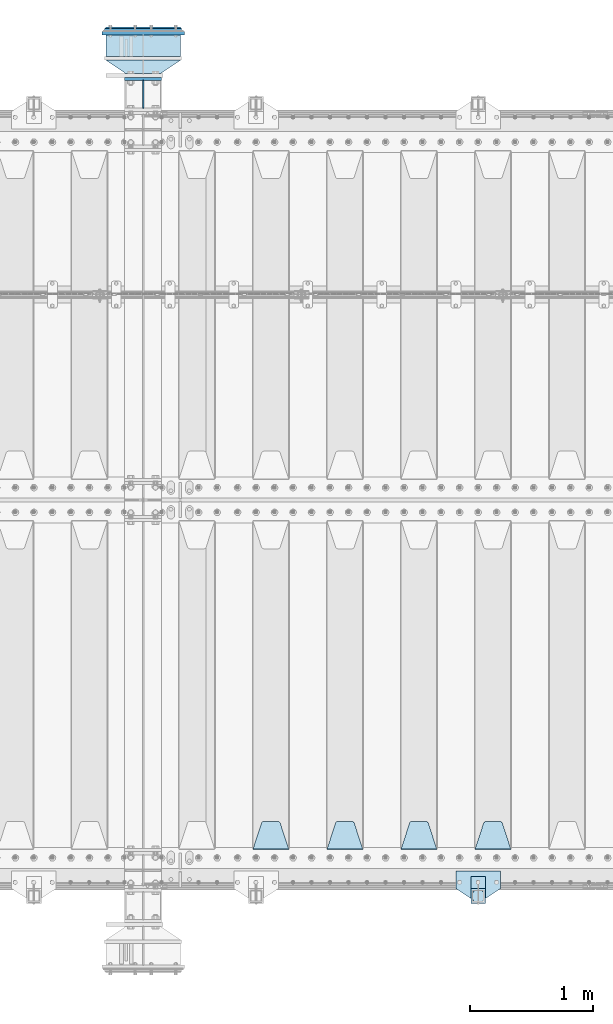
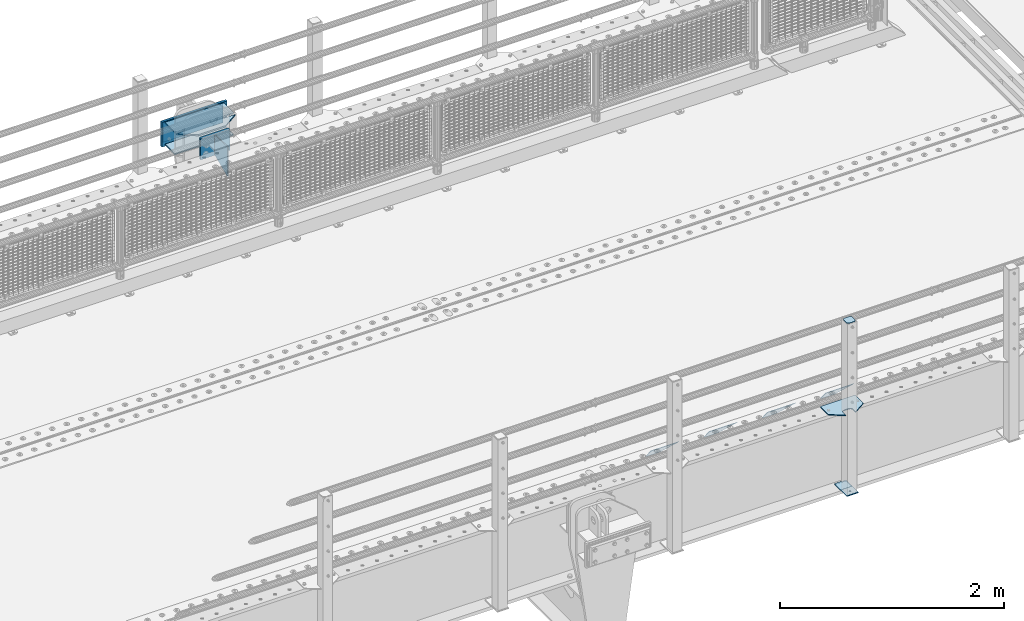
# One storey, part 217 of 242: 15 plates.
"""IFC2X3 building model written with IfcOpenShell, lengths in millimetres."""

from ifc_helpers import new_model, si_unit, frame, origin_with_axes, place, context, subcontext, project, spatial, faceted_brep, material, type_object, element, save


model = new_model("IFC2X3")

# Units and contexts
model_context = context("Model", 3, precision=1e-05, world=origin_with_axes())
body_context = subcontext(model_context, "Body", "Model", "MODEL_VIEW")
ifc_project = project(units=[si_unit("LENGTHUNIT", "METRE", prefix="MILLI"), si_unit("AREAUNIT", "SQUARE_METRE"), si_unit("VOLUMEUNIT", "CUBIC_METRE"), si_unit("MASSUNIT", "GRAM", prefix="KILO"), si_unit("TIMEUNIT", "SECOND"), si_unit("PLANEANGLEUNIT", "RADIAN"), si_unit("SOLIDANGLEUNIT", "STERADIAN"), si_unit("THERMODYNAMICTEMPERATUREUNIT", "DEGREE_CELSIUS"), si_unit("LUMINOUSINTENSITYUNIT", "LUMEN")], contexts=[model_context])

# Site, building, storey
site_placement = place(None, origin_with_axes())
site = spatial("IfcSite", under=ifc_project, at=site_placement, CompositionType="ELEMENT")
building_placement = place(site_placement, origin_with_axes())
building = spatial("IfcBuilding", under=site, at=building_placement, Name="Standard", CompositionType="ELEMENT")
storey_placement = place(building_placement, origin_with_axes())
storey = spatial("IfcBuildingStorey", under=building, at=storey_placement, Name="Undefined", CompositionType="ELEMENT", Elevation=0.0)

# Plates
ifc_material_1 = material(Name="STEEL/S355J2")
plate_type_1 = type_object("IfcPlateType", PredefinedType="NOTDEFINED")
plate_1_placement = place(storey_placement, frame((-25520.0, -24005.0, 5.00000000004911), z_axis=(0.0, -1.0, 0.0), x_axis=(-1.0, 0.0, 0.0)))
element("IfcPlate", 1, at=plate_1_placement, inside=storey, type_object=plate_type_1, material=ifc_material_1, context=body_context, shape_type="Brep", body=[
    faceted_brep([(0.0, -5.0, 0.0), (2.31396552408114e-06, -5.0, 145.0), (2.31396552408114e-06, 5.0, 145.0), (0.0, 5.0, 0.0), (130.0, -5.0, 230.0), (130.0, 5.0, 230.0), (130.0, -5.0, 180.0), (130.0, 5.0, 180.0), (130.48036798992, -5.0, 175.122741949595), (130.48036798992, 5.0, 175.122741949595), (131.903011687216, -5.0, 170.432914190871), (131.903011687216, 5.0, 170.432914190871), (134.213259692435, -5.0, 166.110744174512), (134.213259692435, 5.0, 166.110744174512), (137.322330470335, -5.0, 162.322330470335), (137.322330470335, 5.0, 162.322330470335), (141.110744174512, -5.0, 159.213259692435), (141.110744174512, 5.0, 159.213259692435), (145.432914190871, -5.0, 156.903011687216), (145.432914190871, 5.0, 156.903011687216), (150.122741949595, -5.0, 155.48036798992), (150.122741949595, 5.0, 155.48036798992), (155.0, -5.0, 155.0), (155.0, 5.0, 155.0), (205.0, -5.0, 155.0), (205.0, 5.0, 155.0), (209.877258050405, -5.0, 155.48036798992), (209.877258050405, 5.0, 155.48036798992), (214.567085809129, -5.0, 156.903011687216), (214.567085809129, 5.0, 156.903011687216), (218.889255825488, -5.0, 159.213259692435), (218.889255825488, 5.0, 159.213259692435), (222.677669529665, -5.0, 162.322330470335), (222.677669529665, 5.0, 162.322330470335), (225.786740307565, -5.0, 166.110744174512), (225.786740307565, 5.0, 166.110744174512), (228.096988312784, -5.0, 170.432914190871), (228.096988312784, 5.0, 170.432914190871), (229.51963201008, -5.0, 175.122741949595), (229.51963201008, 5.0, 175.122741949595), (230.0, -5.0, 180.0), (230.0, 5.0, 180.0), (230.0, -5.0, 230.0), (230.0, 5.0, 230.0), (360.0, -5.0, 145.0), (360.0, 5.0, 145.0), (360.0, -5.0, -7.27595761418343e-12), (360.0, 5.0, -7.27595761418343e-12)], [[[0, 1, 2, 3]], [[1, 4, 5, 2]], [[4, 6, 7, 5]], [[6, 8, 9, 7]], [[8, 10, 11, 9]], [[10, 12, 13, 11]], [[12, 14, 15, 13]], [[14, 16, 17, 15]], [[16, 18, 19, 17]], [[18, 20, 21, 19]], [[20, 22, 23, 21]], [[22, 24, 25, 23]], [[24, 26, 27, 25]], [[26, 28, 29, 27]], [[28, 30, 31, 29]], [[30, 32, 33, 31]], [[32, 34, 35, 33]], [[34, 36, 37, 35]], [[36, 38, 39, 37]], [[38, 40, 41, 39]], [[40, 42, 43, 41]], [[42, 44, 45, 43]], [[44, 46, 47, 45]], [[46, 0, 3, 47]], [[5, 7, 9, 11, 13, 15, 17, 19, 21, 23, 25, 27, 29, 31, 33, 35, 37, 39, 41, 43, 45, 47, 3, 2]], [[46, 44, 42, 40, 38, 36, 34, 32, 30, 28, 26, 24, 22, 20, 18, 16, 14, 12, 10, 8, 6, 4, 1, 0]]]),
])
plate_type_2 = type_object("IfcPlateType", PredefinedType="NOTDEFINED")
plate_2_placement = place(storey_placement, frame((-25640.0000000001, -24050.0000000002, -850.000000000002), z_axis=(0.0, -1.0, 0.0), x_axis=(-1.0, 0.0, 0.0)))
element("IfcPlate", 2, at=plate_2_placement, inside=storey, type_object=plate_type_2, material=ifc_material_1, context=body_context, shape_type="Brep", body=[
    faceted_brep([(53.6360389691836, -5.0, 176.363961030471), (53.6360389691836, 5.0, 176.363961030471), (59.9999999998618, 5.0, 178.999999999793), (59.9999999998618, -5.0, 178.999999999793), (66.3639610305399, 5.0, 176.363961030471), (66.3639610305399, -5.0, 176.363961030471), (68.9999999998618, 5.0, 169.999999999793), (68.9999999998618, -5.0, 169.999999999793), (66.3639610305399, 5.0, 163.636038969114), (66.3639610305399, -5.0, 163.636038969114), (59.9999999998618, 5.0, 160.999999999793), (59.9999999998618, -5.0, 160.999999999793), (53.6360389691836, 5.0, 163.636038969114), (53.6360389691836, -5.0, 163.636038969114), (50.9999999998618, 5.0, 169.999999999793), (50.9999999998618, -5.0, 169.999999999793), (120.0, -5.0, 0.0), (120.0, -5.0, 220.0), (0.0, -5.0, 220.0), (0.0, -5.0, 0.0), (0.0, 5.0, 0.0), (120.0, 5.0, 0.0), (120.0, 5.0, 220.0), (0.0, 5.0, 220.0)], [[[0, 1, 2, 3]], [[3, 2, 4, 5]], [[5, 4, 6, 7]], [[7, 6, 8, 9]], [[9, 8, 10, 11]], [[11, 10, 12, 13]], [[13, 12, 14, 15]], [[15, 14, 1, 0]], [[16, 17, 18, 19], [3, 5, 7, 9, 11, 13, 15, 0]], [[16, 19, 20, 21]], [[17, 16, 21, 22]], [[18, 17, 22, 23]], [[19, 18, 23, 20]], [[22, 21, 20, 23], [10, 8, 6, 4, 2, 1, 14, 12]]]),
])
plate_type_3 = type_object("IfcPlateType", PredefinedType="NOTDEFINED")
plate_3_placement = place(storey_placement, frame((-25744.0000000001, -24166.0000000002, 1012.50000000001), z_axis=(0.0, -1.0, 0.0), x_axis=(1.0, 0.0, 0.0)))
element("IfcPlate", 3, at=plate_3_placement, inside=storey, type_object=plate_type_3, material=ifc_material_1, context=body_context, shape_type="Brep", body=[
    faceted_brep([(0.0, -2.5, 19.0), (0.0, -2.5, 69.0), (0.0, 2.5, 69.0), (0.0, 2.5, 19.0), (0.476369668544066, -2.5, 73.2278977451715), (0.476369668544066, 2.5, 73.2278977451715), (1.88159150985302, -2.5, 77.2437910432345), (1.88159150985302, 2.5, 77.2437910432345), (4.14520183310742, -2.5, 80.8463062353148), (4.14520183310742, 2.5, 80.8463062353148), (7.15369376468516, -2.5, 83.8547981668926), (7.15369376468516, 2.5, 83.8547981668926), (10.7562089567655, -2.5, 86.118408490147), (10.7562089567655, 2.5, 86.118408490147), (14.7721022548285, -2.5, 87.5236303314559), (14.7721022548285, 2.5, 87.5236303314559), (19.0, -2.5, 88.0), (19.0, 2.5, 88.0), (69.0, -2.5, 88.0), (69.0, 2.5, 88.0), (73.2278977451715, -2.5, 87.5236303314559), (73.2278977451715, 2.5, 87.5236303314559), (77.2437910432345, -2.5, 86.118408490147), (77.2437910432345, 2.5, 86.118408490147), (80.8463062353148, -2.5, 83.8547981668926), (80.8463062353148, 2.5, 83.8547981668926), (83.8547981668926, -2.5, 80.8463062353148), (83.8547981668926, 2.5, 80.8463062353148), (86.118408490147, -2.5, 77.2437910432345), (86.118408490147, 2.5, 77.2437910432345), (87.5236303314559, -2.5, 73.2278977451715), (87.5236303314559, 2.5, 73.2278977451715), (88.0, -2.5, 69.0), (88.0, 2.5, 69.0), (88.0, -2.5, 19.0), (88.0, 2.5, 19.0), (87.5236303314559, -2.5, 14.7721022548285), (87.5236303314559, 2.5, 14.7721022548285), (86.118408490147, -2.5, 10.7562089567655), (86.118408490147, 2.5, 10.7562089567655), (83.8547981668926, -2.5, 7.15369376468516), (83.8547981668926, 2.5, 7.15369376468516), (80.8463062353148, -2.5, 4.14520183310742), (80.8463062353148, 2.5, 4.14520183310742), (77.2437910432345, -2.5, 1.88159150985302), (77.2437910432345, 2.5, 1.88159150985302), (73.2278977451715, -2.5, 0.476369668544066), (73.2278977451715, 2.5, 0.476369668544066), (69.0, -2.5, 0.0), (69.0, 2.5, 0.0), (19.0, -2.5, 0.0), (19.0, 2.5, 0.0), (14.7721022548285, -2.5, 0.476369668544066), (14.7721022548285, 2.5, 0.476369668544066), (10.7562089567655, -2.5, 1.88159150985302), (10.7562089567655, 2.5, 1.88159150985302), (7.15369376468516, -2.5, 4.14520183310742), (7.15369376468516, 2.5, 4.14520183310742), (4.14520183310742, -2.5, 7.15369376468516), (4.14520183310742, 2.5, 7.15369376468516), (1.88159150985302, -2.5, 10.7562089567655), (1.88159150985302, 2.5, 10.7562089567655), (0.476369668544066, -2.5, 14.7721022548285), (0.476369668544066, 2.5, 14.7721022548285)], [[[0, 1, 2, 3]], [[1, 4, 5, 2]], [[4, 6, 7, 5]], [[6, 8, 9, 7]], [[8, 10, 11, 9]], [[10, 12, 13, 11]], [[12, 14, 15, 13]], [[14, 16, 17, 15]], [[16, 18, 19, 17]], [[18, 20, 21, 19]], [[20, 22, 23, 21]], [[22, 24, 25, 23]], [[24, 26, 27, 25]], [[26, 28, 29, 27]], [[28, 30, 31, 29]], [[30, 32, 33, 31]], [[32, 34, 35, 33]], [[34, 36, 37, 35]], [[36, 38, 39, 37]], [[38, 40, 41, 39]], [[40, 42, 43, 41]], [[42, 44, 45, 43]], [[44, 46, 47, 45]], [[46, 48, 49, 47]], [[48, 50, 51, 49]], [[50, 52, 53, 51]], [[52, 54, 55, 53]], [[54, 56, 57, 55]], [[56, 58, 59, 57]], [[58, 60, 61, 59]], [[60, 62, 63, 61]], [[62, 0, 3, 63]], [[5, 7, 9, 11, 13, 15, 17, 19, 21, 23, 25, 27, 29, 31, 33, 35, 37, 39, 41, 43, 45, 47, 49, 51, 53, 55, 57, 59, 61, 63, 3, 2]], [[62, 60, 58, 56, 54, 52, 50, 48, 46, 44, 42, 40, 38, 36, 34, 32, 30, 28, 26, 24, 22, 20, 18, 16, 14, 12, 10, 8, 6, 4, 1, 0]]]),
])
plate_type_4 = type_object("IfcPlateType", PredefinedType="NOTDEFINED")
plate_4_placement = place(storey_placement, frame((-25640.0000000001, -24050.0000000002, -857.500000000002), z_axis=(0.0, -1.0, 0.0), x_axis=(-1.0, 0.0, 0.0)))
element("IfcPlate", 4, at=plate_4_placement, inside=storey, type_object=plate_type_4, material=ifc_material_1, context=body_context, shape_type="Brep", body=[
    faceted_brep([(0.0, -2.5, 0.0), (0.0, -2.5, 100.0), (0.0, 2.5, 100.0), (0.0, 2.5, 0.0), (120.0, -2.5, 100.0), (120.0, 2.5, 100.0), (120.0, -2.5, 0.0), (120.0, 2.5, 0.0)], [[[0, 1, 2, 3]], [[1, 4, 5, 2]], [[4, 6, 7, 5]], [[6, 0, 3, 7]], [[5, 7, 3, 2]], [[6, 4, 1, 0]]]),
])
ifc_material_2 = material()
plate_type_5 = type_object("IfcPlateType", PredefinedType="NOTDEFINED")
for number, where, z_axis, x_axis in (
    (5, (-28112.5000000603, -17404.9999999654, -17.0000182219899), (0.0, 1.0, 0.0), (-1.0, 0.0, 0.0)),
    (6, (-28112.5000000603, -17404.9999999654, -253.00001822199), (0.0, 1.0, 0.0), (-1.0, 0.0, 0.0)),
):
    element("IfcPlate", number, at=place(storey_placement, frame(where, z_axis=z_axis, x_axis=x_axis)), inside=storey, type_object=plate_type_5, material=ifc_material_2, context=body_context, shape_type="Brep", body=[
        faceted_brep([(0.0, -7.0, 0.0), (0.0, -7.0, 175.0), (0.0, 7.0, 175.0), (0.0, 7.0, 0.0), (605.0, -7.0, 175.0), (605.0, 7.0, 175.0), (605.0, -7.0, 0.0), (605.0, 7.0, 0.0)], [[[0, 1, 2, 3]], [[1, 4, 5, 2]], [[4, 6, 7, 5]], [[6, 0, 3, 7]], [[5, 7, 3, 2]], [[6, 4, 1, 0]]]),
    ])
ifc_material_3 = material(Name="STEEL/S355N")
plate_type_6 = type_object("IfcPlateType", PredefinedType="NOTDEFINED")
plate_5_placement = place(storey_placement, frame((-28112.5000000603, -17434.9999999654, -17.0000182219899), z_axis=(-0.560566412034006, 0.828109472050236, 0.0), x_axis=(-0.828109472050232, -0.560566412034012, 0.0)))
element("IfcPlate", 7, at=plate_5_placement, inside=storey, type_object=plate_type_6, material=ifc_material_3, context=body_context, shape_type="Brep", body=[
    faceted_brep([(0.0, -7.0, 0.0), (501.006225585945, -7.0, 339.142669677734), (501.006225585945, 7.0, 339.142669677734), (0.0, 7.0, 0.0), (428.100738525391, -7.0, 156.958602905273), (428.100738525391, 7.0, 156.958602905273), (196.230087280281, -7.0, -4.00177668780088e-11), (196.230087280281, 7.0, -4.00177668780088e-11)], [[[0, 1, 2, 3]], [[1, 4, 5, 2]], [[4, 6, 7, 5]], [[6, 0, 3, 7]], [[5, 7, 3, 2]], [[6, 4, 1, 0]]]),
])
plate_type_7 = type_object("IfcPlateType", PredefinedType="NOTDEFINED")
plate_6_placement = place(storey_placement, frame((-28565.0000000603, -17587.4999999654, -250.00001822199), z_axis=(0.0, 0.0, 1.0), x_axis=(1.0, 0.0, 0.0)))
element("IfcPlate", 8, at=plate_6_placement, inside=storey, type_object=plate_type_7, material=ifc_material_3, context=body_context, shape_type="Brep", body=[
    faceted_brep([(0.0, -12.5, 0.0), (0.0, -12.5, 230.0), (0.0, 12.5, 230.0), (0.0, 12.5, 0.0), (300.0, -12.5, 230.0), (300.0, 12.5, 230.0), (300.0, -12.5, 0.0), (300.0, 12.5, 0.0)], [[[0, 1, 2, 3]], [[1, 4, 5, 2]], [[4, 6, 7, 5]], [[6, 0, 3, 7]], [[5, 7, 3, 2]], [[6, 4, 1, 0]]]),
])
ifc_material_4 = material()
plate_type_8 = type_object("IfcPlateType", PredefinedType="NOTDEFINED")
plate_7_placement = place(storey_placement, frame((-28102.5000000603, -17184.9999999654, -22.5000182219899), z_axis=(0.0, 0.0, -1.0), x_axis=(-1.0, 0.0, 0.0)))
element("IfcPlate", 9, at=plate_7_placement, inside=storey, type_object=plate_type_8, material=ifc_material_4, context=body_context, shape_type="Brep", body=[
    faceted_brep([(0.0, -15.0, 0.0), (5.0, -20.0, 5.0), (5.0, -20.0, 220.0), (0.0, -15.0, 225.0), (625.0, -15.0, 0.0), (620.0, -20.0, 5.0), (620.0, -20.0, 220.0), (625.0, -15.0, 225.0), (15.0, 20.0, 15.0), (0.0, 5.0, 0.0), (0.0, 5.0, 225.0), (15.0, 20.0, 210.0), (625.0, 5.0, 225.0), (610.0, 20.0, 210.0), (625.0, 5.0, 0.0), (610.0, 20.0, 15.0), (64.8205080756888, -5.0, 37.5), (57.5, -5.0, 30.1794919243112), (47.5, -5.0, 27.5), (37.5, -5.0, 30.1794919243112), (30.1794919243112, -5.0, 37.5), (27.5, -5.0, 47.5), (30.1794919243112, -5.0, 57.5), (37.5, -5.0, 64.8205080756888), (47.5, -5.0, 67.5), (57.5, -5.0, 64.8205080756888), (64.8205080756888, -5.0, 57.5), (67.5, -5.0, 47.5), (37.5, 20.0, 64.8205080756888), (30.1794919243112, 20.0, 57.5), (47.5, 20.0, 67.5), (57.5, 20.0, 64.8205080756888), (64.8205080756888, 20.0, 57.5), (67.5, 20.0, 47.5), (64.8205080756888, 20.0, 37.5), (57.5, 20.0, 30.1794919243112), (47.5, 20.0, 27.5), (37.5, 20.0, 30.1794919243112), (30.1794919243112, 20.0, 37.5), (27.5, 20.0, 47.5), (264.820508075689, -5.0, 37.5), (257.5, -5.0, 30.1794919243112), (247.5, -5.0, 27.5), (237.5, -5.0, 30.1794919243112), (230.179491924311, -5.0, 37.5), (227.5, -5.0, 47.5), (230.179491924311, -5.0, 57.5), (237.5, -5.0, 64.8205080756888), (247.5, -5.0, 67.5), (257.5, -5.0, 64.8205080756888), (264.820508075689, -5.0, 57.5), (267.5, -5.0, 47.5), (230.179491924311, 20.0, 57.5), (227.5, 20.0, 47.5), (237.5, 20.0, 64.8205080756888), (247.5, 20.0, 67.5), (257.5, 20.0, 64.8205080756888), (264.820508075689, 20.0, 57.5), (267.5, 20.0, 47.5), (264.820508075689, 20.0, 37.5), (257.5, 20.0, 30.1794919243112), (247.5, 20.0, 27.5), (237.5, 20.0, 30.1794919243112), (230.179491924311, 20.0, 37.5), (594.820508075689, -5.0, 37.5), (587.5, -5.0, 30.1794919243112), (577.5, -5.0, 27.5), (567.5, -5.0, 30.1794919243112), (560.179491924311, -5.0, 37.5), (557.5, -5.0, 47.5), (560.179491924311, -5.0, 57.5), (567.5, -5.0, 64.8205080756888), (577.5, -5.0, 67.5), (587.5, -5.0, 64.8205080756888), (594.820508075689, -5.0, 57.5), (597.5, -5.0, 47.5), (560.179491924311, 20.0, 57.5), (557.5, 20.0, 47.5), (567.5, 20.0, 64.8205080756888), (577.5, 20.0, 67.5), (587.5, 20.0, 64.8205080756888), (594.820508075689, 20.0, 57.5), (597.5, 20.0, 47.5), (594.820508075689, 20.0, 37.5), (587.5, 20.0, 30.1794919243112), (577.5, 20.0, 27.5), (567.5, 20.0, 30.1794919243112), (560.179491924311, 20.0, 37.5), (594.820508075689, -5.0, 167.5), (587.5, -5.0, 160.179491924311), (577.5, -5.0, 157.5), (567.5, -5.0, 160.179491924311), (560.179491924311, -5.0, 167.5), (557.5, -5.0, 177.5), (560.179491924311, -5.0, 187.5), (567.5, -5.0, 194.820508075689), (577.5, -5.0, 197.5), (587.5, -5.0, 194.820508075689), (594.820508075689, -5.0, 187.5), (597.5, -5.0, 177.5), (560.179491924311, 20.0, 187.5), (557.5, 20.0, 177.5), (567.5, 20.0, 194.820508075689), (577.5, 20.0, 197.5), (587.5, 20.0, 194.820508075689), (594.820508075689, 20.0, 187.5), (597.5, 20.0, 177.5), (594.820508075689, 20.0, 167.5), (587.5, 20.0, 160.179491924311), (577.5, 20.0, 157.5), (567.5, 20.0, 160.179491924311), (560.179491924311, 20.0, 167.5), (264.820508075689, -5.0, 167.5), (257.5, -5.0, 160.179491924311), (247.5, -5.0, 157.5), (237.5, -5.0, 160.179491924311), (230.179491924311, -5.0, 167.5), (227.5, -5.0, 177.5), (230.179491924311, -5.0, 187.5), (237.5, -5.0, 194.820508075689), (247.5, -5.0, 197.5), (257.5, -5.0, 194.820508075689), (264.820508075689, -5.0, 187.5), (267.5, -5.0, 177.5), (230.179491924311, 20.0, 187.5), (227.5, 20.0, 177.5), (237.5, 20.0, 194.820508075689), (247.5, 20.0, 197.5), (257.5, 20.0, 194.820508075689), (264.820508075689, 20.0, 187.5), (267.5, 20.0, 177.5), (264.820508075689, 20.0, 167.5), (257.5, 20.0, 160.179491924311), (247.5, 20.0, 157.5), (237.5, 20.0, 160.179491924311), (230.179491924311, 20.0, 167.5), (64.8205080756888, -5.0, 167.5), (57.5, -5.0, 160.179491924311), (47.5, -5.0, 157.5), (37.5, -5.0, 160.179491924311), (30.1794919243112, -5.0, 167.5), (27.5, -5.0, 177.5), (30.1794919243112, -5.0, 187.5), (37.5, -5.0, 194.820508075689), (47.5, -5.0, 197.5), (57.5, -5.0, 194.820508075689), (64.8205080756888, -5.0, 187.5), (67.5, -5.0, 177.5), (30.1794919243112, 20.0, 187.5), (27.5, 20.0, 177.5), (37.5, 20.0, 194.820508075689), (47.5, 20.0, 197.5), (57.5, 20.0, 194.820508075689), (64.8205080756888, 20.0, 187.5), (67.5, 20.0, 177.5), (64.8205080756888, 20.0, 167.5), (57.5, 20.0, 160.179491924311), (47.5, 20.0, 157.5), (37.5, 20.0, 160.179491924311), (30.1794919243112, 20.0, 167.5), (394.820508075689, -5.0, 167.5), (387.5, -5.0, 160.179491924311), (377.5, -5.0, 157.5), (367.5, -5.0, 160.179491924311), (360.179491924311, -5.0, 167.5), (357.5, -5.0, 177.5), (360.179491924311, -5.0, 187.5), (367.5, -5.0, 194.820508075689), (377.5, -5.0, 197.5), (387.5, -5.0, 194.820508075689), (394.820508075689, -5.0, 187.5), (397.5, -5.0, 177.5), (360.179491924311, 20.0, 187.5), (357.5, 20.0, 177.5), (367.5, 20.0, 194.820508075689), (377.5, 20.0, 197.5), (387.5, 20.0, 194.820508075689), (394.820508075689, 20.0, 187.5), (397.5, 20.0, 177.5), (394.820508075689, 20.0, 167.5), (387.5, 20.0, 160.179491924311), (377.5, 20.0, 157.5), (367.5, 20.0, 160.179491924311), (360.179491924311, 20.0, 167.5), (394.820508075689, -5.0, 37.5), (387.5, -5.0, 30.1794919243112), (377.5, -5.0, 27.5), (367.5, -5.0, 30.1794919243112), (360.179491924311, -5.0, 37.5), (357.5, -5.0, 47.5), (360.179491924311, -5.0, 57.5), (367.5, -5.0, 64.8205080756888), (377.5, -5.0, 67.5), (387.5, -5.0, 64.8205080756888), (394.820508075689, -5.0, 57.5), (397.5, -5.0, 47.5), (360.179491924311, 20.0, 57.5), (357.5, 20.0, 47.5), (367.5, 20.0, 64.8205080756888), (377.5, 20.0, 67.5), (387.5, 20.0, 64.8205080756888), (394.820508075689, 20.0, 57.5), (397.5, 20.0, 47.5), (394.820508075689, 20.0, 37.5), (387.5, 20.0, 30.1794919243112), (377.5, 20.0, 27.5), (367.5, 20.0, 30.1794919243112), (360.179491924311, 20.0, 37.5)], [[[0, 1, 2, 3]], [[4, 5, 1, 0]], [[6, 7, 3, 2]], [[7, 6, 5, 4]], [[8, 9, 10, 11]], [[12, 13, 11, 10]], [[14, 15, 13, 12]], [[15, 14, 9, 8]], [[16, 17, 18, 19, 20, 21, 22, 23, 24, 25, 26, 27]], [[28, 23, 22, 29]], [[30, 24, 23, 28]], [[31, 25, 24, 30]], [[32, 26, 25, 31]], [[33, 27, 26, 32]], [[34, 16, 27, 33]], [[35, 17, 16, 34]], [[36, 18, 17, 35]], [[37, 19, 18, 36]], [[38, 20, 19, 37]], [[39, 21, 20, 38]], [[29, 22, 21, 39]], [[5, 6, 2, 1]], [[9, 14, 4, 0]], [[14, 12, 7, 4]], [[12, 10, 3, 7]], [[10, 9, 0, 3]], [[40, 41, 42, 43, 44, 45, 46, 47, 48, 49, 50, 51]], [[52, 46, 45, 53]], [[54, 47, 46, 52]], [[55, 48, 47, 54]], [[56, 49, 48, 55]], [[57, 50, 49, 56]], [[58, 51, 50, 57]], [[59, 40, 51, 58]], [[60, 41, 40, 59]], [[61, 42, 41, 60]], [[62, 43, 42, 61]], [[63, 44, 43, 62]], [[53, 45, 44, 63]], [[64, 65, 66, 67, 68, 69, 70, 71, 72, 73, 74, 75]], [[76, 70, 69, 77]], [[78, 71, 70, 76]], [[79, 72, 71, 78]], [[80, 73, 72, 79]], [[81, 74, 73, 80]], [[82, 75, 74, 81]], [[83, 64, 75, 82]], [[84, 65, 64, 83]], [[85, 66, 65, 84]], [[86, 67, 66, 85]], [[87, 68, 67, 86]], [[77, 69, 68, 87]], [[88, 89, 90, 91, 92, 93, 94, 95, 96, 97, 98, 99]], [[100, 94, 93, 101]], [[102, 95, 94, 100]], [[103, 96, 95, 102]], [[104, 97, 96, 103]], [[105, 98, 97, 104]], [[106, 99, 98, 105]], [[107, 88, 99, 106]], [[108, 89, 88, 107]], [[109, 90, 89, 108]], [[110, 91, 90, 109]], [[111, 92, 91, 110]], [[101, 93, 92, 111]], [[112, 113, 114, 115, 116, 117, 118, 119, 120, 121, 122, 123]], [[124, 118, 117, 125]], [[126, 119, 118, 124]], [[127, 120, 119, 126]], [[128, 121, 120, 127]], [[129, 122, 121, 128]], [[130, 123, 122, 129]], [[131, 112, 123, 130]], [[132, 113, 112, 131]], [[133, 114, 113, 132]], [[134, 115, 114, 133]], [[135, 116, 115, 134]], [[125, 117, 116, 135]], [[136, 137, 138, 139, 140, 141, 142, 143, 144, 145, 146, 147]], [[148, 142, 141, 149]], [[150, 143, 142, 148]], [[151, 144, 143, 150]], [[152, 145, 144, 151]], [[153, 146, 145, 152]], [[154, 147, 146, 153]], [[155, 136, 147, 154]], [[156, 137, 136, 155]], [[157, 138, 137, 156]], [[158, 139, 138, 157]], [[159, 140, 139, 158]], [[149, 141, 140, 159]], [[160, 161, 162, 163, 164, 165, 166, 167, 168, 169, 170, 171]], [[172, 166, 165, 173]], [[174, 167, 166, 172]], [[175, 168, 167, 174]], [[176, 169, 168, 175]], [[177, 170, 169, 176]], [[178, 171, 170, 177]], [[179, 160, 171, 178]], [[180, 161, 160, 179]], [[181, 162, 161, 180]], [[182, 163, 162, 181]], [[183, 164, 163, 182]], [[173, 165, 164, 183]], [[184, 185, 186, 187, 188, 189, 190, 191, 192, 193, 194, 195]], [[196, 190, 189, 197]], [[198, 191, 190, 196]], [[199, 192, 191, 198]], [[200, 193, 192, 199]], [[201, 194, 193, 200]], [[202, 195, 194, 201]], [[203, 184, 195, 202]], [[204, 185, 184, 203]], [[205, 186, 185, 204]], [[206, 187, 186, 205]], [[207, 188, 187, 206]], [[197, 189, 188, 207]], [[13, 15, 8, 11], [37, 36, 35, 34, 33, 32, 31, 30, 28, 29, 39, 38], [206, 205, 204, 203, 202, 201, 200, 199, 198, 196, 197, 207], [182, 181, 180, 179, 178, 177, 176, 175, 174, 172, 173, 183], [158, 157, 156, 155, 154, 153, 152, 151, 150, 148, 149, 159], [134, 133, 132, 131, 130, 129, 128, 127, 126, 124, 125, 135], [110, 109, 108, 107, 106, 105, 104, 103, 102, 100, 101, 111], [86, 85, 84, 83, 82, 81, 80, 79, 78, 76, 77, 87], [62, 61, 60, 59, 58, 57, 56, 55, 54, 52, 53, 63]]]),
])
plate_type_9 = type_object("IfcPlateType", PredefinedType="NOTDEFINED")
plate_8_placement = place(storey_placement, frame((-28080.0000000603, -17217.4999999654, -1.82219898761105e-05), z_axis=(0.0, 0.0, -1.0), x_axis=(-1.0, 0.0, 0.0)))
element("IfcPlate", 10, at=plate_8_placement, inside=storey, type_object=plate_type_9, material=ifc_material_3, context=body_context, shape_type="Brep", body=[
    faceted_brep([(0.0, -12.5, 0.0), (0.0, -12.5, 270.0), (0.0, 12.5, 270.0), (0.0, 12.5, 0.0), (670.0, -12.5, 270.0), (670.0, 12.5, 270.0), (670.0, -12.5, 0.0), (670.0, 12.5, 0.0)], [[[0, 1, 2, 3]], [[1, 4, 5, 2]], [[4, 6, 7, 5]], [[6, 0, 3, 7]], [[5, 7, 3, 2]], [[6, 4, 1, 0]]]),
])
plate_type_10 = type_object("IfcPlateType", PredefinedType="NOTDEFINED")
plate_9_placement = place(storey_placement, frame((-28415.0000000603, -17824.9999999654, -346.00001822199), z_axis=(0.0, 1.0, 0.0), x_axis=(0.0, 0.0, 1.0)))
element("IfcPlate", 11, at=plate_9_placement, inside=storey, type_object=plate_type_10, material=ifc_material_3, context=body_context, shape_type="Brep", body=[
    faceted_brep([(0.0, -5.0, 0.0), (100.0, -5.0, 225.0), (100.0, 5.0, 225.0), (0.0, 5.0, 0.0), (322.0, -5.0, 225.0), (322.0, 5.0, 225.0), (322.0, -5.0, 0.0), (322.0, 5.0, 0.0)], [[[0, 1, 2, 3]], [[1, 4, 5, 2]], [[4, 6, 7, 5]], [[6, 0, 3, 7]], [[5, 7, 3, 2]], [[6, 4, 1, 0]]]),
])
plate_type_11 = type_object("IfcPlateType", PredefinedType="NOTDEFINED")
plate_10_placement = place(storey_placement, frame((-25435.0, -23831.767766953, -1.76776695296758), z_axis=(0.0, 0.707106781186547, -0.707106781186548), x_axis=(-1.0, 0.0, 0.0)))
element("IfcPlate", 12, at=plate_10_placement, inside=storey, type_object=plate_type_11, material=ifc_material_3, context=body_context, shape_type="Brep", body=[
    faceted_brep([(0.0, -2.5, 0.0), (69.345504679477, -2.50000000000182, 300.171731424829), (69.345504679477, 2.5, 300.171731424829), (0.0, 2.5, 0.0), (70.9274061199576, -2.5, 304.897442415398), (70.9274061199576, 2.5, 304.897442415398), (73.3818627772307, -2.5, 309.234538108525), (73.3818627772307, 2.50000000000182, 309.234538108529), (76.6187032999551, -2.5, 313.023683126101), (76.6187032999551, 2.50000000000182, 313.023683126103), (80.5190132704993, -2.5, 316.12567259537), (80.5190132704993, 2.5, 316.12567259537), (84.9395038596849, -2.5, 318.426546230474), (84.9395038596849, 2.50000000000182, 318.426546230476), (89.7177759439219, -2.49999999999818, 319.841774983273), (89.7177759439219, 2.50000000000182, 319.841774983273), (94.678286292652, -2.5, 320.319366455076), (94.678286292652, 2.5, 320.319366455076), (195.321713707348, -2.5, 320.319366455076), (195.321713707348, 2.5, 320.319366455076), (200.282224056078, -2.5, 319.841774983272), (200.282224056078, 2.50000000000182, 319.841774983273), (205.060496140315, -2.5, 318.426546230474), (205.060496140315, 2.49999999999818, 318.426546230474), (209.480986729501, -2.49999999999818, 316.12567259537), (209.480986729501, 2.5, 316.12567259537), (213.381296700045, -2.5, 313.023683126101), (213.381296700045, 2.49999999999818, 313.023683126101), (216.618137222769, -2.5, 309.234538108525), (216.618137222769, 2.5, 309.234538108523), (219.072593880042, -2.49999999999818, 304.897442415398), (219.072593880042, 2.50000000000182, 304.897442415398), (220.654495320523, -2.50000000000182, 300.171731424829), (220.654495320523, 2.5, 300.171731424829), (290.0, -2.5, 0.0), (290.0, 2.5, -1.81898940354586e-12)], [[[0, 1, 2, 3]], [[1, 4, 5, 2]], [[4, 6, 7, 5]], [[6, 8, 9, 7]], [[8, 10, 11, 9]], [[10, 12, 13, 11]], [[12, 14, 15, 13]], [[14, 16, 17, 15]], [[16, 18, 19, 17]], [[18, 20, 21, 19]], [[20, 22, 23, 21]], [[22, 24, 25, 23]], [[24, 26, 27, 25]], [[26, 28, 29, 27]], [[28, 30, 31, 29]], [[30, 32, 33, 31]], [[32, 34, 35, 33]], [[34, 0, 3, 35]], [[5, 7, 9, 11, 13, 15, 17, 19, 21, 23, 25, 27, 29, 31, 33, 35, 3, 2]], [[34, 32, 30, 28, 26, 24, 22, 20, 18, 16, 14, 12, 10, 8, 6, 4, 1, 0]]]),
])
plate_11_placement = place(storey_placement, frame((-26035.0, -23831.767766953, -1.76776695296758), z_axis=(0.0, 0.707106781186547, -0.707106781186548), x_axis=(-1.0, 0.0, 0.0)))
element("IfcPlate", 13, at=plate_11_placement, inside=storey, type_object=plate_type_11, material=ifc_material_3, context=body_context, shape_type="Brep", body=[
    faceted_brep([(0.0, -2.5, 0.0), (69.345504679477, -2.50000000000182, 300.171731424829), (69.345504679477, 2.5, 300.171731424829), (0.0, 2.5, 0.0), (70.9274061199576, -2.5, 304.897442415398), (70.9274061199576, 2.5, 304.897442415398), (73.3818627772307, -2.5, 309.234538108525), (73.3818627772307, 2.50000000000182, 309.234538108529), (76.6187032999551, -2.5, 313.023683126101), (76.6187032999551, 2.50000000000182, 313.023683126103), (80.5190132704993, -2.5, 316.12567259537), (80.5190132704993, 2.5, 316.12567259537), (84.9395038596849, -2.5, 318.426546230474), (84.9395038596849, 2.50000000000182, 318.426546230476), (89.7177759439219, -2.49999999999818, 319.841774983273), (89.7177759439219, 2.50000000000182, 319.841774983273), (94.678286292652, -2.5, 320.319366455076), (94.678286292652, 2.5, 320.319366455076), (195.321713707348, -2.5, 320.319366455076), (195.321713707348, 2.5, 320.319366455076), (200.282224056078, -2.5, 319.841774983272), (200.282224056078, 2.50000000000182, 319.841774983273), (205.060496140315, -2.5, 318.426546230474), (205.060496140315, 2.49999999999818, 318.426546230474), (209.480986729501, -2.49999999999818, 316.12567259537), (209.480986729501, 2.5, 316.12567259537), (213.381296700045, -2.5, 313.023683126101), (213.381296700045, 2.49999999999818, 313.023683126101), (216.618137222769, -2.5, 309.234538108525), (216.618137222769, 2.5, 309.234538108523), (219.072593880042, -2.49999999999818, 304.897442415398), (219.072593880042, 2.50000000000182, 304.897442415398), (220.654495320523, -2.50000000000182, 300.171731424829), (220.654495320523, 2.5, 300.171731424829), (290.0, -2.5, 0.0), (290.0, 2.5, -1.81898940354586e-12)], [[[0, 1, 2, 3]], [[1, 4, 5, 2]], [[4, 6, 7, 5]], [[6, 8, 9, 7]], [[8, 10, 11, 9]], [[10, 12, 13, 11]], [[12, 14, 15, 13]], [[14, 16, 17, 15]], [[16, 18, 19, 17]], [[18, 20, 21, 19]], [[20, 22, 23, 21]], [[22, 24, 25, 23]], [[24, 26, 27, 25]], [[26, 28, 29, 27]], [[28, 30, 31, 29]], [[30, 32, 33, 31]], [[32, 34, 35, 33]], [[34, 0, 3, 35]], [[5, 7, 9, 11, 13, 15, 17, 19, 21, 23, 25, 27, 29, 31, 33, 35, 3, 2]], [[34, 32, 30, 28, 26, 24, 22, 20, 18, 16, 14, 12, 10, 8, 6, 4, 1, 0]]]),
])
plate_12_placement = place(storey_placement, frame((-26635.0, -23831.767766953, -1.76776695296758), z_axis=(0.0, 0.707106781186547, -0.707106781186548), x_axis=(-1.0, 0.0, 0.0)))
element("IfcPlate", 14, at=plate_12_placement, inside=storey, type_object=plate_type_11, material=ifc_material_3, context=body_context, shape_type="Brep", body=[
    faceted_brep([(0.0, -2.5, 0.0), (69.345504679477, -2.50000000000182, 300.171731424829), (69.345504679477, 2.5, 300.171731424829), (0.0, 2.5, 0.0), (70.9274061199576, -2.5, 304.897442415398), (70.9274061199576, 2.5, 304.897442415398), (73.3818627772307, -2.5, 309.234538108525), (73.3818627772307, 2.50000000000182, 309.234538108529), (76.6187032999551, -2.5, 313.023683126101), (76.6187032999551, 2.50000000000182, 313.023683126103), (80.5190132704993, -2.5, 316.12567259537), (80.5190132704993, 2.5, 316.12567259537), (84.9395038596849, -2.5, 318.426546230474), (84.9395038596849, 2.50000000000182, 318.426546230476), (89.7177759439219, -2.49999999999818, 319.841774983273), (89.7177759439219, 2.50000000000182, 319.841774983273), (94.678286292652, -2.5, 320.319366455076), (94.678286292652, 2.5, 320.319366455076), (195.321713707348, -2.5, 320.319366455076), (195.321713707348, 2.5, 320.319366455076), (200.282224056078, -2.5, 319.841774983272), (200.282224056078, 2.50000000000182, 319.841774983273), (205.060496140315, -2.5, 318.426546230474), (205.060496140315, 2.49999999999818, 318.426546230474), (209.480986729501, -2.49999999999818, 316.12567259537), (209.480986729501, 2.5, 316.12567259537), (213.381296700045, -2.5, 313.023683126101), (213.381296700045, 2.49999999999818, 313.023683126101), (216.618137222769, -2.5, 309.234538108525), (216.618137222769, 2.5, 309.234538108523), (219.072593880042, -2.49999999999818, 304.897442415398), (219.072593880042, 2.50000000000182, 304.897442415398), (220.654495320523, -2.50000000000182, 300.171731424829), (220.654495320523, 2.5, 300.171731424829), (290.0, -2.5, 0.0), (290.0, 2.5, -1.81898940354586e-12)], [[[0, 1, 2, 3]], [[1, 4, 5, 2]], [[4, 6, 7, 5]], [[6, 8, 9, 7]], [[8, 10, 11, 9]], [[10, 12, 13, 11]], [[12, 14, 15, 13]], [[14, 16, 17, 15]], [[16, 18, 19, 17]], [[18, 20, 21, 19]], [[20, 22, 23, 21]], [[22, 24, 25, 23]], [[24, 26, 27, 25]], [[26, 28, 29, 27]], [[28, 30, 31, 29]], [[30, 32, 33, 31]], [[32, 34, 35, 33]], [[34, 0, 3, 35]], [[5, 7, 9, 11, 13, 15, 17, 19, 21, 23, 25, 27, 29, 31, 33, 35, 3, 2]], [[34, 32, 30, 28, 26, 24, 22, 20, 18, 16, 14, 12, 10, 8, 6, 4, 1, 0]]]),
])
plate_13_placement = place(storey_placement, frame((-27235.0, -23831.767766953, -1.76776695296758), z_axis=(0.0, 0.707106781186547, -0.707106781186548), x_axis=(-1.0, 0.0, 0.0)))
element("IfcPlate", 15, at=plate_13_placement, inside=storey, type_object=plate_type_11, material=ifc_material_3, context=body_context, shape_type="Brep", body=[
    faceted_brep([(0.0, -2.5, 0.0), (69.345504679477, -2.50000000000182, 300.171731424829), (69.345504679477, 2.5, 300.171731424829), (0.0, 2.5, 0.0), (70.9274061199576, -2.5, 304.897442415398), (70.9274061199576, 2.5, 304.897442415398), (73.3818627772307, -2.5, 309.234538108525), (73.3818627772307, 2.50000000000182, 309.234538108529), (76.6187032999551, -2.5, 313.023683126101), (76.6187032999551, 2.50000000000182, 313.023683126103), (80.5190132704993, -2.5, 316.12567259537), (80.5190132704993, 2.5, 316.12567259537), (84.9395038596849, -2.5, 318.426546230474), (84.9395038596849, 2.50000000000182, 318.426546230476), (89.7177759439219, -2.49999999999818, 319.841774983273), (89.7177759439219, 2.50000000000182, 319.841774983273), (94.678286292652, -2.5, 320.319366455076), (94.678286292652, 2.5, 320.319366455076), (195.321713707348, -2.5, 320.319366455076), (195.321713707348, 2.5, 320.319366455076), (200.282224056078, -2.5, 319.841774983272), (200.282224056078, 2.50000000000182, 319.841774983273), (205.060496140315, -2.5, 318.426546230474), (205.060496140315, 2.49999999999818, 318.426546230474), (209.480986729501, -2.49999999999818, 316.12567259537), (209.480986729501, 2.5, 316.12567259537), (213.381296700045, -2.5, 313.023683126101), (213.381296700045, 2.49999999999818, 313.023683126101), (216.618137222769, -2.5, 309.234538108525), (216.618137222769, 2.5, 309.234538108523), (219.072593880042, -2.49999999999818, 304.897442415398), (219.072593880042, 2.50000000000182, 304.897442415398), (220.654495320523, -2.50000000000182, 300.171731424829), (220.654495320523, 2.5, 300.171731424829), (290.0, -2.5, 0.0), (290.0, 2.5, -1.81898940354586e-12)], [[[0, 1, 2, 3]], [[1, 4, 5, 2]], [[4, 6, 7, 5]], [[6, 8, 9, 7]], [[8, 10, 11, 9]], [[10, 12, 13, 11]], [[12, 14, 15, 13]], [[14, 16, 17, 15]], [[16, 18, 19, 17]], [[18, 20, 21, 19]], [[20, 22, 23, 21]], [[22, 24, 25, 23]], [[24, 26, 27, 25]], [[26, 28, 29, 27]], [[28, 30, 31, 29]], [[30, 32, 33, 31]], [[32, 34, 35, 33]], [[34, 0, 3, 35]], [[5, 7, 9, 11, 13, 15, 17, 19, 21, 23, 25, 27, 29, 31, 33, 35, 3, 2]], [[34, 32, 30, 28, 26, 24, 22, 20, 18, 16, 14, 12, 10, 8, 6, 4, 1, 0]]]),
])

save(model, "model.ifc")
